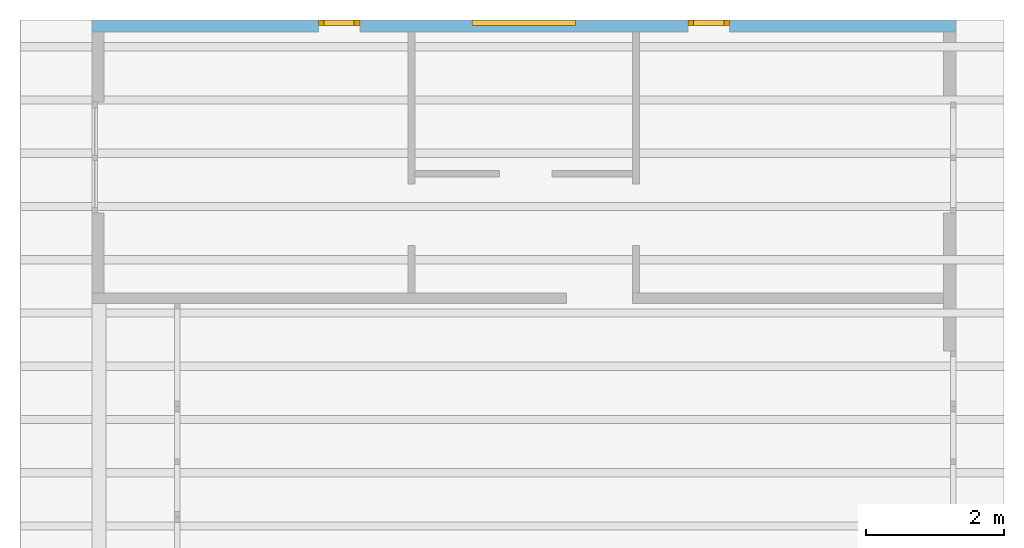
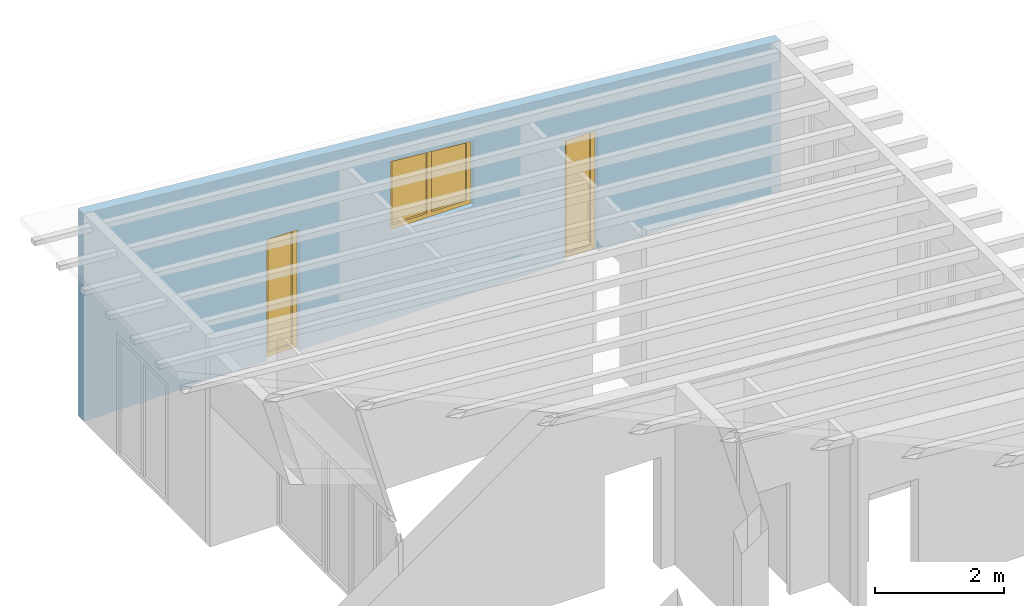
# One storey, part 13 of 13: 3 windows, 3 openings, plus 1 element that does not belong to this part.
"""IFC2X3 building model written with IfcOpenShell, lengths in millimetres."""

from ifc_helpers import new_model, entity, si_unit, converted_unit, frame, frame_2d, origin, origin_with_axes, place, context, project, spatial, polyline, rectangle, outline, extrude, clip, halfspace, faceted_brep, material, layer, layer_set, layer_usage, element, fill, save


model = new_model("IFC2X3")

# Units and contexts
model_context = context("Model", 3, precision=1e-05, world=origin())
plan_context = context("Plan", 3, precision=1e-05, world=origin())
ifc_project = project(units=[si_unit("LENGTHUNIT", "METRE", prefix="MILLI"), converted_unit("PLANEANGLEUNIT", "DEGREE", entity("IfcPlaneAngleMeasure", 0.0174532925199433), si_unit("PLANEANGLEUNIT", "RADIAN"), dimensions=[0, 0, 0, 0, 0, 0, 0]), si_unit("AREAUNIT", "SQUARE_METRE"), si_unit("VOLUMEUNIT", "CUBIC_METRE")], contexts=[model_context, plan_context])

# Building, storey
building_placement = place(None, origin())
building = spatial("IfcBuilding", under=ifc_project, at=building_placement, CompositionType="ELEMENT")
storey_placement = place(building_placement, frame((0.0, 0.0, 4770.0), z_axis=(0.0, 0.0, 1.0), x_axis=(1.0, 0.0, 0.0)))
storey = spatial("IfcBuildingStorey", under=building, at=storey_placement, Name="Geschoss", CompositionType="ELEMENT", Elevation=4770.0)

# Wall, openings, windows
ifc_material_1 = material()
ifc_layer = layer(ifc_material_1, 175.0)
ifc_layer_set = layer_set([ifc_layer])
ifc_layer_usage = layer_usage(ifc_layer_set, "AXIS2", "POSITIVE", 0.0)
wall_placement = place(storey_placement, frame((33688.3517822139, 9808.4375, 0.0), z_axis=(0.0, 0.0, 1.0), x_axis=(-1.0, 0.0, 0.0)))
wall = element("IfcWallStandardCase", 1, at=wall_placement, inside=storey, material=ifc_layer_usage, context=model_context, shape_type="Clipping", body=[
    clip(extrude(rectangle(XDim=12500.0, YDim=175.0, at=frame_2d((6250.0, 87.5), x_axis=(1.0, 0.0))), origin_with_axes(), (0.0, 0.0, 1.0), 3940.60829407405), halfspace(frame((0.0, 175.0, 2847.0), z_axis=(0.0871557427476578, 0.0, -0.996194698091746), x_axis=(1.0, 0.0, 0.0)), True)),
])
opening_1_placement = place(wall_placement, frame((5500.00000001148, 0.0, 1635.0), z_axis=(0.0, 1.0, 0.0), x_axis=(0.0, 0.0, 1.0)))
opening_1 = element("IfcOpeningElement", 2, at=opening_1_placement, cuts=wall, ObjectType="Opening", context=model_context, shape_type="SweptSolid", body=[
    extrude(outline(polyline([(0.0, 0.0), (1243.18764939358, 0.0), (1374.42064468247, 1500.0), (0.0, 1500.0), (0.0, 0.0)])), origin_with_axes(), (0.0, 0.0, 1.0), 175.0),
])
opening_2_placement = place(wall_placement, frame((3274.9999999553, 0.0, 0.0), z_axis=(0.0, 1.0, 0.0), x_axis=(0.0, 0.0, 1.0)))
opening_2 = element("IfcOpeningElement", 3, at=opening_2_placement, cuts=wall, ObjectType="Opening", context=model_context, shape_type="SweptSolid", body=[
    extrude(rectangle(XDim=2300.0, YDim=600.0, at=frame_2d((1150.0, 300.0), x_axis=(1.0, 0.0))), origin_with_axes(), (0.0, 0.0, 1.0), 175.0),
])
opening_3_placement = place(wall_placement, frame((8625.0000000447, 0.0, 0.0), z_axis=(0.0, 1.0, 0.0), x_axis=(0.0, 0.0, 1.0)))
opening_3 = element("IfcOpeningElement", 4, at=opening_3_placement, cuts=wall, ObjectType="Opening", context=model_context, shape_type="SweptSolid", body=[
    extrude(rectangle(XDim=2300.0, YDim=600.0, at=frame_2d((1150.0, 300.0), x_axis=(1.0, 0.0))), origin_with_axes(), (0.0, 0.0, 1.0), 175.0),
])
ifc_material_2 = material()
window_1_placement = place(opening_1_placement, frame((0.0, 0.0, 0.0), z_axis=(1.0, 0.0, 0.0), x_axis=(0.0, 1.0, 0.0)))
window_1 = element("IfcWindow", 5, at=window_1_placement, inside=storey, material=ifc_material_2, Name="m", OverallHeight=1374.42064468247, OverallWidth=1500.0, context=model_context, shape_type="Brep", body=[
    faceted_brep([(1420.0, 4.23280299699513e-11, 0.0), (1420.0, 4.23280299699513e-11, 1367.4215516004), (1500.0, 4.23084900447179e-11, 1374.42064468247), (1500.0, 4.23084900447179e-11, 0.0), (1500.0, 80.0000000000423, 0.0), (1500.0, 80.0000000000423, 1374.42064468247), (1420.0, 80.0000000000423, 1367.4215516004), (1420.0, 80.0000000000423, 0.0), (1500.0, 4.23084900447179e-11, 0.0), (1500.0, 80.0000000000423, 0.0), (1420.0, 80.0000000000423, 0.0), (1420.0, 4.23280299699513e-11, 0.0), (1500.0, 4.23084900447179e-11, 1374.42064468247), (1500.0, 80.0000000000423, 1374.42064468247), (1500.0, 80.0000000000423, 0.0), (1500.0, 4.23084900447179e-11, 0.0), (1420.0, 4.23280299699513e-11, 1367.4215516004), (1420.0, 80.0000000000423, 1367.4215516004), (1500.0, 80.0000000000423, 1374.42064468247), (1500.0, 4.23084900447179e-11, 1374.42064468247), (1420.0, 4.23280299699513e-11, 0.0), (1420.0, 80.0000000000423, 0.0), (1420.0, 80.0000000000423, 1367.4215516004), (1420.0, 4.23280299699513e-11, 1367.4215516004)], [[[0, 1, 2, 3]], [[4, 5, 6, 7]], [[8, 9, 10, 11]], [[12, 13, 14, 15]], [[16, 17, 18, 19]], [[20, 21, 22, 23]]], orient=[[False], [False], [False], [False], [False], [False]]),
    faceted_brep([(80.0, 4.26669810593694e-11, 1250.18674247566), (80.0, 4.26669810593694e-11, 0.0), (-1.46952762455441e-16, 4.26865209846028e-11, 0.0), (-1.46952762455441e-16, 4.26865209846028e-11, 1243.18764939358), (1.94467488987026e-14, 80.0000000000427, 1243.18764939358), (1.94467488987026e-14, 80.0000000000427, 0.0), (80.0, 80.0000000000427, 0.0), (80.0, 80.0000000000427, 1250.18674247566), (-1.46952762455441e-16, 4.26865209846028e-11, 1243.18764939358), (1.94467488987026e-14, 80.0000000000427, 1243.18764939358), (80.0, 80.0000000000427, 1250.18674247566), (80.0, 4.26669810593694e-11, 1250.18674247566), (-1.46952762455441e-16, 4.26865209846028e-11, 0.0), (1.94467488987026e-14, 80.0000000000427, 0.0), (1.94467488987026e-14, 80.0000000000427, 1243.18764939358), (-1.46952762455441e-16, 4.26865209846028e-11, 1243.18764939358), (80.0, 4.26669810593694e-11, 0.0), (80.0, 80.0000000000427, 0.0), (1.94467488987026e-14, 80.0000000000427, 0.0), (-1.46952762455441e-16, 4.26865209846028e-11, 0.0), (80.0, 4.26669810593694e-11, 1250.18674247566), (80.0, 80.0000000000427, 1250.18674247566), (80.0, 80.0000000000427, 0.0), (80.0, 4.26669810593694e-11, 0.0)], [[[0, 1, 2, 3]], [[4, 5, 6, 7]], [[8, 9, 10, 11]], [[12, 13, 14, 15]], [[16, 17, 18, 19]], [[20, 21, 22, 23]]], orient=[[False], [False], [False], [False], [False], [False]]),
    faceted_brep([(1420.0, 4.23706625340969e-11, 1287.11596459693), (80.0, 4.26989554824786e-11, 1169.88115547219), (80.0, 4.26989554824786e-11, 1250.18674247566), (1420.0, 4.23706625340969e-11, 1367.4215516004), (1420.0, 80.0000000000424, 1367.4215516004), (80.0, 80.0000000000427, 1250.18674247566), (80.0, 80.0000000000427, 1169.88115547219), (1420.0, 80.0000000000424, 1287.11596459693), (1420.0, 4.23706625340969e-11, 1367.4215516004), (1420.0, 80.0000000000424, 1367.4215516004), (1420.0, 80.0000000000424, 1287.11596459693), (1420.0, 4.23706625340969e-11, 1287.11596459693), (80.0, 4.26989554824786e-11, 1250.18674247566), (80.0, 80.0000000000427, 1250.18674247566), (1420.0, 80.0000000000424, 1367.4215516004), (1420.0, 4.23706625340969e-11, 1367.4215516004), (80.0, 4.26989554824786e-11, 1169.88115547219), (80.0, 80.0000000000427, 1169.88115547219), (80.0, 80.0000000000427, 1250.18674247566), (80.0, 4.26989554824786e-11, 1250.18674247566), (1420.0, 4.23706625340969e-11, 1287.11596459693), (1420.0, 80.0000000000424, 1287.11596459693), (80.0, 80.0000000000427, 1169.88115547219), (80.0, 4.26989554824786e-11, 1169.88115547219)], [[[0, 1, 2, 3]], [[4, 5, 6, 7]], [[8, 9, 10, 11]], [[12, 13, 14, 15]], [[16, 17, 18, 19]], [[20, 21, 22, 23]]], orient=[[False], [False], [False], [False], [False], [False]]),
    faceted_brep([(80.0, 4.26989554824786e-11, 80.0), (1420.0, 4.23706625340969e-11, 80.0), (1420.0, 4.23706625340969e-11, 0.0), (80.0, 4.26989554824786e-11, 0.0), (80.0, 80.0000000000427, 0.0), (1420.0, 80.0000000000424, 0.0), (1420.0, 80.0000000000424, 80.0), (80.0, 80.0000000000427, 80.0), (80.0, 4.26989554824786e-11, 0.0), (80.0, 80.0000000000427, 0.0), (80.0, 80.0000000000427, 80.0), (80.0, 4.26989554824786e-11, 80.0), (1420.0, 4.23706625340969e-11, 0.0), (1420.0, 80.0000000000424, 0.0), (80.0, 80.0000000000427, 0.0), (80.0, 4.26989554824786e-11, 0.0), (1420.0, 4.23706625340969e-11, 80.0), (1420.0, 80.0000000000424, 80.0), (1420.0, 80.0000000000424, 0.0), (1420.0, 4.23706625340969e-11, 0.0), (80.0, 4.26989554824786e-11, 80.0), (80.0, 80.0000000000427, 80.0), (1420.0, 80.0000000000424, 80.0), (1420.0, 4.23706625340969e-11, 80.0)], [[[0, 1, 2, 3]], [[4, 5, 6, 7]], [[8, 9, 10, 11]], [[12, 13, 14, 15]], [[16, 17, 18, 19]], [[20, 21, 22, 23]]], orient=[[False], [False], [False], [False], [False], [False]]),
    faceted_brep([(710.0, 4.25126600589465e-11, 80.0), (710.0, 4.25126600589465e-11, 1224.99901349352), (790.0, 4.24930091114106e-11, 1231.9981065756), (790.0, 4.24930091114106e-11, 80.0), (790.0, 80.0000000000425, 80.0), (790.0, 80.0000000000425, 1231.9981065756), (710.0, 80.0000000000425, 1224.99901349352), (710.0, 80.0000000000425, 80.0), (790.0, 4.24930091114106e-11, 80.0), (790.0, 80.0000000000425, 80.0), (710.0, 80.0000000000425, 80.0), (710.0, 4.25126600589465e-11, 80.0), (790.0, 4.24930091114106e-11, 1231.9981065756), (790.0, 80.0000000000425, 1231.9981065756), (790.0, 80.0000000000425, 80.0), (790.0, 4.24930091114106e-11, 80.0), (710.0, 4.25126600589465e-11, 1224.99901349352), (710.0, 80.0000000000425, 1224.99901349352), (790.0, 80.0000000000425, 1231.9981065756), (790.0, 4.24930091114106e-11, 1231.9981065756), (710.0, 4.25126600589465e-11, 80.0), (710.0, 80.0000000000425, 80.0), (710.0, 80.0000000000425, 1224.99901349352), (710.0, 4.25126600589465e-11, 1224.99901349352)], [[[0, 1, 2, 3]], [[4, 5, 6, 7]], [[8, 9, 10, 11]], [[12, 13, 14, 15]], [[16, 17, 18, 19]], [[20, 21, 22, 23]]], orient=[[False], [False], [False], [False], [False], [False]]),
    faceted_brep([(80.0, 40.0000000000427, 1169.88115547219), (710.0, 40.0000000000425, 1224.99901349352), (710.0, 40.0000000000425, 80.0), (80.0, 40.0000000000427, 80.0), (80.0, 41.0000000000427, 1169.88115547219), (80.0, 41.0000000000427, 80.0), (710.0, 41.0000000000425, 80.0), (710.0, 41.0000000000425, 1224.99901349352), (80.0, 40.0000000000427, 1169.88115547219), (80.0, 41.0000000000427, 1169.88115547219), (710.0, 41.0000000000425, 1224.99901349352), (710.0, 40.0000000000425, 1224.99901349352), (710.0, 40.0000000000425, 1224.99901349352), (710.0, 41.0000000000425, 1224.99901349352), (710.0, 41.0000000000425, 80.0), (710.0, 40.0000000000425, 80.0), (710.0, 40.0000000000425, 80.0), (710.0, 41.0000000000425, 80.0), (80.0, 41.0000000000427, 80.0), (80.0, 40.0000000000427, 80.0), (80.0, 40.0000000000427, 80.0), (80.0, 41.0000000000427, 80.0), (80.0, 41.0000000000427, 1169.88115547219), (80.0, 40.0000000000427, 1169.88115547219)], [[[0, 1, 2, 3]], [[4, 5, 6, 7]], [[8, 9, 10, 11]], [[12, 13, 14, 15]], [[16, 17, 18, 19]], [[20, 21, 22, 23]]], orient=[[False], [False], [False], [False], [False], [False]]),
    faceted_brep([(1420.0, 40.0000000000424, 80.0), (790.0, 40.0000000000425, 80.0), (790.0, 40.0000000000425, 1231.9981065756), (1420.0, 40.0000000000424, 1287.11596459693), (1420.0, 41.0000000000424, 80.0), (1420.0, 41.0000000000424, 1287.11596459693), (790.0, 41.0000000000425, 1231.9981065756), (790.0, 41.0000000000425, 80.0), (1420.0, 40.0000000000424, 80.0), (1420.0, 41.0000000000424, 80.0), (790.0, 41.0000000000425, 80.0), (790.0, 40.0000000000425, 80.0), (790.0, 40.0000000000425, 80.0), (790.0, 41.0000000000425, 80.0), (790.0, 41.0000000000425, 1231.9981065756), (790.0, 40.0000000000425, 1231.9981065756), (790.0, 40.0000000000425, 1231.9981065756), (790.0, 41.0000000000425, 1231.9981065756), (1420.0, 41.0000000000424, 1287.11596459693), (1420.0, 40.0000000000424, 1287.11596459693), (1420.0, 40.0000000000424, 1287.11596459693), (1420.0, 41.0000000000424, 1287.11596459693), (1420.0, 41.0000000000424, 80.0), (1420.0, 40.0000000000424, 80.0)], [[[0, 1, 2, 3]], [[4, 5, 6, 7]], [[8, 9, 10, 11]], [[12, 13, 14, 15]], [[16, 17, 18, 19]], [[20, 21, 22, 23]]], orient=[[False], [False], [False], [False], [False], [False]]),
])
fill(opening_1, window_1)
ifc_material_3 = material()
window_2_placement = place(opening_2_placement, frame((0.0, 0.0, 0.0), z_axis=(1.0, 0.0, 0.0), x_axis=(0.0, 1.0, 0.0)))
window_2 = element("IfcWindow", 6, at=window_2_placement, inside=storey, material=ifc_material_3, Name="m", OverallHeight=2300.0, OverallWidth=600.0, context=model_context, shape_type="Brep", body=[
    faceted_brep([(80.0, 4.28287405540573e-11, 0.0), (0.0, 4.28483915015931e-11, 0.0), (0.0, 4.28483915015931e-11, 2300.0), (80.0, 4.28287405540573e-11, 2300.0), (0.0, 80.0000000000428, 0.0), (80.0, 80.0000000000428, 0.0), (80.0, 80.0000000000428, 2300.0), (0.0, 80.0000000000428, 2300.0), (0.0, 4.28483915015931e-11, 0.0), (80.0, 4.28287405540573e-11, 0.0), (80.0, 80.0000000000428, 0.0), (0.0, 80.0000000000428, 0.0), (0.0, 4.28483915015931e-11, 2300.0), (0.0, 4.28483915015931e-11, 0.0), (0.0, 80.0000000000428, 0.0), (0.0, 80.0000000000428, 2300.0), (80.0, 4.28287405540573e-11, 2300.0), (0.0, 4.28483915015931e-11, 2300.0), (0.0, 80.0000000000428, 2300.0), (80.0, 80.0000000000428, 2300.0), (80.0, 4.28287405540573e-11, 0.0), (80.0, 4.28287405540573e-11, 2300.0), (80.0, 80.0000000000428, 2300.0), (80.0, 80.0000000000428, 0.0)], [[[0, 1, 2, 3]], [[4, 5, 6, 7]], [[8, 9, 10, 11]], [[12, 13, 14, 15]], [[16, 17, 18, 19]], [[20, 21, 22, 23]]], orient=[[False], [False], [False], [False], [False], [False]]),
    faceted_brep([(520.0, 4.2706727043651e-11, 2300.0), (600.0, 4.26871871184176e-11, 2300.0), (600.0, 4.26871871184176e-11, 0.0), (520.0, 4.2706727043651e-11, 0.0), (600.0, 80.0000000000427, 2300.0), (520.0, 80.0000000000427, 2300.0), (520.0, 80.0000000000427, 0.0), (600.0, 80.0000000000427, 0.0), (600.0, 4.26871871184176e-11, 2300.0), (520.0, 4.2706727043651e-11, 2300.0), (520.0, 80.0000000000427, 2300.0), (600.0, 80.0000000000427, 2300.0), (600.0, 4.26871871184176e-11, 0.0), (600.0, 4.26871871184176e-11, 2300.0), (600.0, 80.0000000000427, 2300.0), (600.0, 80.0000000000427, 0.0), (520.0, 4.2706727043651e-11, 0.0), (600.0, 4.26871871184176e-11, 0.0), (600.0, 80.0000000000427, 0.0), (520.0, 80.0000000000427, 0.0), (520.0, 4.2706727043651e-11, 2300.0), (520.0, 4.2706727043651e-11, 0.0), (520.0, 80.0000000000427, 0.0), (520.0, 80.0000000000427, 2300.0)], [[[0, 1, 2, 3]], [[4, 5, 6, 7]], [[8, 9, 10, 11]], [[12, 13, 14, 15]], [[16, 17, 18, 19]], [[20, 21, 22, 23]]], orient=[[False], [False], [False], [False], [False], [False]]),
    faceted_brep([(80.0, 4.28003188446269e-11, 2220.0), (80.0, 4.28003188446269e-11, 2300.0), (520.0, 4.26925161889358e-11, 2300.0), (520.0, 4.26925161889358e-11, 2220.0), (80.0, 80.0000000000428, 2300.0), (80.0, 80.0000000000428, 2220.0), (520.0, 80.0000000000427, 2220.0), (520.0, 80.0000000000427, 2300.0), (80.0, 4.28003188446269e-11, 2300.0), (80.0, 4.28003188446269e-11, 2220.0), (80.0, 80.0000000000428, 2220.0), (80.0, 80.0000000000428, 2300.0), (520.0, 4.26925161889358e-11, 2300.0), (80.0, 4.28003188446269e-11, 2300.0), (80.0, 80.0000000000428, 2300.0), (520.0, 80.0000000000427, 2300.0), (520.0, 4.26925161889358e-11, 2220.0), (520.0, 4.26925161889358e-11, 2300.0), (520.0, 80.0000000000427, 2300.0), (520.0, 80.0000000000427, 2220.0), (80.0, 4.28003188446269e-11, 2220.0), (520.0, 4.26925161889358e-11, 2220.0), (520.0, 80.0000000000427, 2220.0), (80.0, 80.0000000000428, 2220.0)], [[[0, 1, 2, 3]], [[4, 5, 6, 7]], [[8, 9, 10, 11]], [[12, 13, 14, 15]], [[16, 17, 18, 19]], [[20, 21, 22, 23]]], orient=[[False], [False], [False], [False], [False], [False]]),
    faceted_brep([(520.0, 4.26925161889358e-11, 80.0), (520.0, 4.26925161889358e-11, 0.0), (80.0, 4.28003188446269e-11, 0.0), (80.0, 4.28003188446269e-11, 80.0), (520.0, 80.0000000000427, 0.0), (520.0, 80.0000000000427, 80.0), (80.0, 80.0000000000428, 80.0), (80.0, 80.0000000000428, 0.0), (520.0, 4.26925161889358e-11, 0.0), (520.0, 4.26925161889358e-11, 80.0), (520.0, 80.0000000000427, 80.0), (520.0, 80.0000000000427, 0.0), (80.0, 4.28003188446269e-11, 0.0), (520.0, 4.26925161889358e-11, 0.0), (520.0, 80.0000000000427, 0.0), (80.0, 80.0000000000428, 0.0), (80.0, 4.28003188446269e-11, 80.0), (80.0, 4.28003188446269e-11, 0.0), (80.0, 80.0000000000428, 0.0), (80.0, 80.0000000000428, 80.0), (520.0, 4.26925161889358e-11, 80.0), (80.0, 4.28003188446269e-11, 80.0), (80.0, 80.0000000000428, 80.0), (520.0, 80.0000000000427, 80.0)], [[[0, 1, 2, 3]], [[4, 5, 6, 7]], [[8, 9, 10, 11]], [[12, 13, 14, 15]], [[16, 17, 18, 19]], [[20, 21, 22, 23]]], orient=[[False], [False], [False], [False], [False], [False]]),
    faceted_brep([(80.0, 40.0000000000428, 80.0), (80.0, 40.0000000000428, 2220.0), (520.0, 40.0000000000427, 2220.0), (520.0, 40.0000000000427, 80.0), (80.0, 41.0000000000428, 80.0), (520.0, 41.0000000000427, 80.0), (520.0, 41.0000000000427, 2220.0), (80.0, 41.0000000000428, 2220.0), (80.0, 40.0000000000428, 80.0), (80.0, 41.0000000000428, 80.0), (80.0, 41.0000000000428, 2220.0), (80.0, 40.0000000000428, 2220.0), (80.0, 40.0000000000428, 2220.0), (80.0, 41.0000000000428, 2220.0), (520.0, 41.0000000000427, 2220.0), (520.0, 40.0000000000427, 2220.0), (520.0, 40.0000000000427, 2220.0), (520.0, 41.0000000000427, 2220.0), (520.0, 41.0000000000427, 80.0), (520.0, 40.0000000000427, 80.0), (520.0, 40.0000000000427, 80.0), (520.0, 41.0000000000427, 80.0), (80.0, 41.0000000000428, 80.0), (80.0, 40.0000000000428, 80.0)], [[[0, 1, 2, 3]], [[4, 5, 6, 7]], [[8, 9, 10, 11]], [[12, 13, 14, 15]], [[16, 17, 18, 19]], [[20, 21, 22, 23]]], orient=[[False], [False], [False], [False], [False], [False]]),
])
fill(opening_2, window_2)
ifc_material_4 = material()
window_3_placement = place(opening_3_placement, frame((0.0, 0.0, 0.0), z_axis=(1.0, 0.0, 0.0), x_axis=(0.0, 1.0, 0.0)))
window_3 = element("IfcWindow", 7, at=window_3_placement, inside=storey, material=ifc_material_4, Name="m", OverallHeight=2300.0, OverallWidth=600.0, context=model_context, shape_type="Brep", body=[
    faceted_brep([(80.0, 4.28287405540573e-11, 0.0), (0.0, 4.28483915015931e-11, 0.0), (0.0, 4.28483915015931e-11, 2300.0), (80.0, 4.28287405540573e-11, 2300.0), (0.0, 80.0000000000428, 0.0), (80.0, 80.0000000000428, 0.0), (80.0, 80.0000000000428, 2300.0), (0.0, 80.0000000000428, 2300.0), (0.0, 4.28483915015931e-11, 0.0), (80.0, 4.28287405540573e-11, 0.0), (80.0, 80.0000000000428, 0.0), (0.0, 80.0000000000428, 0.0), (0.0, 4.28483915015931e-11, 2300.0), (0.0, 4.28483915015931e-11, 0.0), (0.0, 80.0000000000428, 0.0), (0.0, 80.0000000000428, 2300.0), (80.0, 4.28287405540573e-11, 2300.0), (0.0, 4.28483915015931e-11, 2300.0), (0.0, 80.0000000000428, 2300.0), (80.0, 80.0000000000428, 2300.0), (80.0, 4.28287405540573e-11, 0.0), (80.0, 4.28287405540573e-11, 2300.0), (80.0, 80.0000000000428, 2300.0), (80.0, 80.0000000000428, 0.0)], [[[0, 1, 2, 3]], [[4, 5, 6, 7]], [[8, 9, 10, 11]], [[12, 13, 14, 15]], [[16, 17, 18, 19]], [[20, 21, 22, 23]]], orient=[[False], [False], [False], [False], [False], [False]]),
    faceted_brep([(520.0, 4.2706727043651e-11, 2300.0), (600.0, 4.26871871184176e-11, 2300.0), (600.0, 4.26871871184176e-11, 0.0), (520.0, 4.2706727043651e-11, 0.0), (600.0, 80.0000000000427, 2300.0), (520.0, 80.0000000000427, 2300.0), (520.0, 80.0000000000427, 0.0), (600.0, 80.0000000000427, 0.0), (600.0, 4.26871871184176e-11, 2300.0), (520.0, 4.2706727043651e-11, 2300.0), (520.0, 80.0000000000427, 2300.0), (600.0, 80.0000000000427, 2300.0), (600.0, 4.26871871184176e-11, 0.0), (600.0, 4.26871871184176e-11, 2300.0), (600.0, 80.0000000000427, 2300.0), (600.0, 80.0000000000427, 0.0), (520.0, 4.2706727043651e-11, 0.0), (600.0, 4.26871871184176e-11, 0.0), (600.0, 80.0000000000427, 0.0), (520.0, 80.0000000000427, 0.0), (520.0, 4.2706727043651e-11, 2300.0), (520.0, 4.2706727043651e-11, 0.0), (520.0, 80.0000000000427, 0.0), (520.0, 80.0000000000427, 2300.0)], [[[0, 1, 2, 3]], [[4, 5, 6, 7]], [[8, 9, 10, 11]], [[12, 13, 14, 15]], [[16, 17, 18, 19]], [[20, 21, 22, 23]]], orient=[[False], [False], [False], [False], [False], [False]]),
    faceted_brep([(80.0, 4.28003188446269e-11, 2220.0), (80.0, 4.28003188446269e-11, 2300.0), (520.0, 4.26925161889358e-11, 2300.0), (520.0, 4.26925161889358e-11, 2220.0), (80.0, 80.0000000000428, 2300.0), (80.0, 80.0000000000428, 2220.0), (520.0, 80.0000000000427, 2220.0), (520.0, 80.0000000000427, 2300.0), (80.0, 4.28003188446269e-11, 2300.0), (80.0, 4.28003188446269e-11, 2220.0), (80.0, 80.0000000000428, 2220.0), (80.0, 80.0000000000428, 2300.0), (520.0, 4.26925161889358e-11, 2300.0), (80.0, 4.28003188446269e-11, 2300.0), (80.0, 80.0000000000428, 2300.0), (520.0, 80.0000000000427, 2300.0), (520.0, 4.26925161889358e-11, 2220.0), (520.0, 4.26925161889358e-11, 2300.0), (520.0, 80.0000000000427, 2300.0), (520.0, 80.0000000000427, 2220.0), (80.0, 4.28003188446269e-11, 2220.0), (520.0, 4.26925161889358e-11, 2220.0), (520.0, 80.0000000000427, 2220.0), (80.0, 80.0000000000428, 2220.0)], [[[0, 1, 2, 3]], [[4, 5, 6, 7]], [[8, 9, 10, 11]], [[12, 13, 14, 15]], [[16, 17, 18, 19]], [[20, 21, 22, 23]]], orient=[[False], [False], [False], [False], [False], [False]]),
    faceted_brep([(520.0, 4.26925161889358e-11, 80.0), (520.0, 4.26925161889358e-11, 0.0), (80.0, 4.28003188446269e-11, 0.0), (80.0, 4.28003188446269e-11, 80.0), (520.0, 80.0000000000427, 0.0), (520.0, 80.0000000000427, 80.0), (80.0, 80.0000000000428, 80.0), (80.0, 80.0000000000428, 0.0), (520.0, 4.26925161889358e-11, 0.0), (520.0, 4.26925161889358e-11, 80.0), (520.0, 80.0000000000427, 80.0), (520.0, 80.0000000000427, 0.0), (80.0, 4.28003188446269e-11, 0.0), (520.0, 4.26925161889358e-11, 0.0), (520.0, 80.0000000000427, 0.0), (80.0, 80.0000000000428, 0.0), (80.0, 4.28003188446269e-11, 80.0), (80.0, 4.28003188446269e-11, 0.0), (80.0, 80.0000000000428, 0.0), (80.0, 80.0000000000428, 80.0), (520.0, 4.26925161889358e-11, 80.0), (80.0, 4.28003188446269e-11, 80.0), (80.0, 80.0000000000428, 80.0), (520.0, 80.0000000000427, 80.0)], [[[0, 1, 2, 3]], [[4, 5, 6, 7]], [[8, 9, 10, 11]], [[12, 13, 14, 15]], [[16, 17, 18, 19]], [[20, 21, 22, 23]]], orient=[[False], [False], [False], [False], [False], [False]]),
    faceted_brep([(80.0, 40.0000000000428, 80.0), (80.0, 40.0000000000428, 2220.0), (520.0, 40.0000000000427, 2220.0), (520.0, 40.0000000000427, 80.0), (80.0, 41.0000000000428, 80.0), (520.0, 41.0000000000427, 80.0), (520.0, 41.0000000000427, 2220.0), (80.0, 41.0000000000428, 2220.0), (80.0, 40.0000000000428, 80.0), (80.0, 41.0000000000428, 80.0), (80.0, 41.0000000000428, 2220.0), (80.0, 40.0000000000428, 2220.0), (80.0, 40.0000000000428, 2220.0), (80.0, 41.0000000000428, 2220.0), (520.0, 41.0000000000427, 2220.0), (520.0, 40.0000000000427, 2220.0), (520.0, 40.0000000000427, 2220.0), (520.0, 41.0000000000427, 2220.0), (520.0, 41.0000000000427, 80.0), (520.0, 40.0000000000427, 80.0), (520.0, 40.0000000000427, 80.0), (520.0, 41.0000000000427, 80.0), (80.0, 41.0000000000428, 80.0), (80.0, 40.0000000000428, 80.0)], [[[0, 1, 2, 3]], [[4, 5, 6, 7]], [[8, 9, 10, 11]], [[12, 13, 14, 15]], [[16, 17, 18, 19]], [[20, 21, 22, 23]]], orient=[[False], [False], [False], [False], [False], [False]]),
])
fill(opening_3, window_3)

save(model, "model.ifc")
